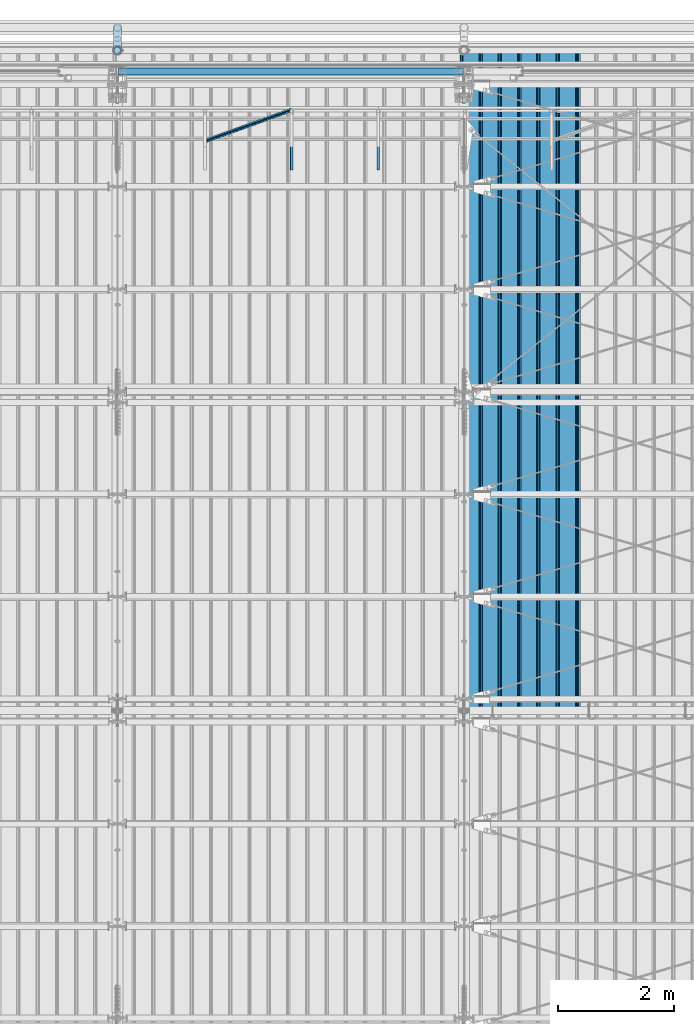
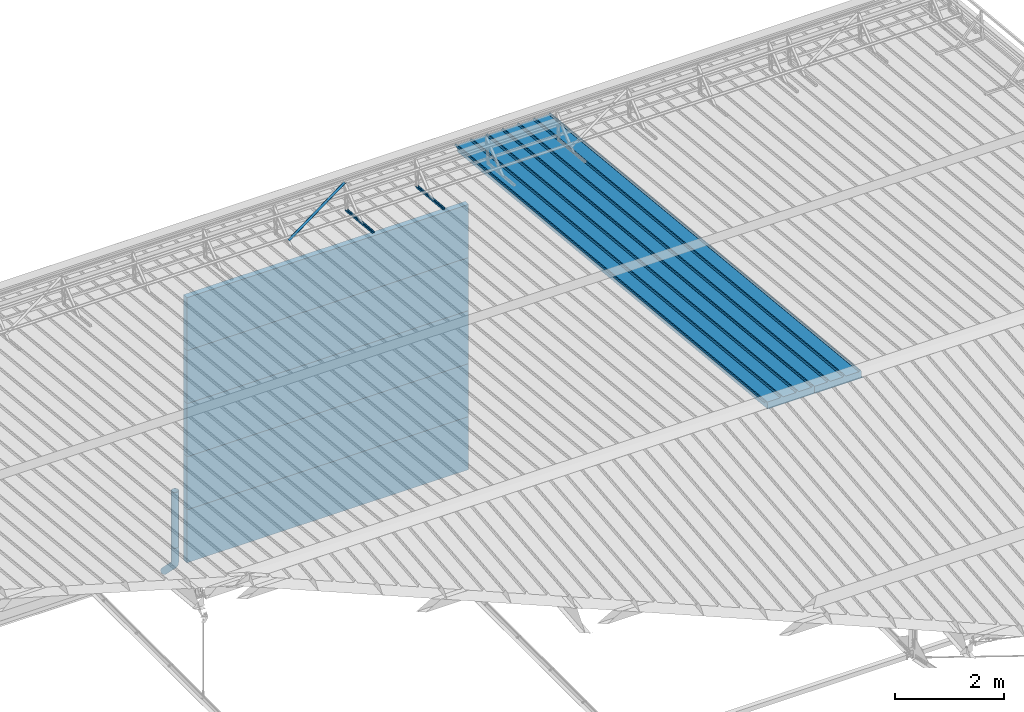
# One storey, part 76 of 709: 12 beams, 12 elements without a shape of their own.
"""IFC4 building model written with IfcOpenShell, lengths in millimetres."""

import ifcopenshell
import ifcopenshell.guid

model = None  # the IFC model being written
_history = None  # IfcOwnerHistory: only IFC2X3 demands one
_inside = {}  # id of a spatial element -> (the spatial element, [elements in it])
_under = {}  # id of a project, library or spatial element -> (it, [spatial elements below it])
_declared = {}  # id of a project -> (the project, [libraries it declares])
_typed = {}  # id of a type object -> (the type object, [elements of that type])
_made_of = {}  # id of a material, layer set ... -> (it, [elements and type objects made of it])


def new_model(schema):
    """Start an empty IFC model of exactly this schema.

    Asked for "IFC4X3", IfcOpenShell would pick the latest addendum, in which some entities
    have other attributes; the version numbers below select the first issue.
    IFC2X3 requires an IfcOwnerHistory on every rooted entity: one is made here for all.
    """
    global model, _history
    if schema == "IFC4X3":
        model = ifcopenshell.file(schema_version=(4, 3, 0, 0))
    else:
        model = ifcopenshell.file(schema=schema)
    _inside.clear()
    _under.clear()
    _declared.clear()
    _typed.clear()
    _made_of.clear()
    _history = None
    if model.schema == "IFC2X3":
        org = make("IfcOrganization", Name="unknown")
        user = make(
            "IfcPersonAndOrganization",
            ThePerson=make("IfcPerson", FamilyName="unknown"),
            TheOrganization=org,
        )
        app = make(
            "IfcApplication",
            ApplicationDeveloper=org,
            Version="unknown",
            ApplicationFullName="unknown",
            ApplicationIdentifier="unknown",
        )
        _history = make(
            "IfcOwnerHistory",
            OwningUser=user,
            OwningApplication=app,
            ChangeAction="ADDED",
            CreationDate=0,
        )
    return model


def make(cls, **values):
    """One entity of the class cls with the attributes given. An attribute that is None is left unset."""
    return model.create_entity(
        cls, **{name: value for name, value in values.items() if value is not None}
    )


def entity(cls, *values):
    """Any entity or typed value of the class cls, its attributes in the order of the schema. None: left unset."""
    e = model.create_entity(cls)
    for i, value in enumerate(values):
        if value is not None:
            e[i] = value
    return e


def rooted(cls, **values):
    """An entity with a GlobalId (a new one), such as an element, a storey or a relation."""
    return make(cls, GlobalId=ifcopenshell.guid.new(), OwnerHistory=_history, **values)


def si_unit(unit_type, name, prefix=None):
    """IfcSIUnit, for example si_unit("LENGTHUNIT", "METRE", prefix="MILLI")."""
    return make("IfcSIUnit", UnitType=unit_type, Prefix=prefix, Name=name)


def assignment(units):
    """IfcUnitAssignment: the units of a project."""
    return None if units is None else make("IfcUnitAssignment", Units=units)


def point(xyz):
    """IfcCartesianPoint."""
    return None if xyz is None else make("IfcCartesianPoint", Coordinates=xyz)


def direction(xyz):
    """IfcDirection."""
    return None if xyz is None else make("IfcDirection", DirectionRatios=xyz)


def frame(location, z_axis=None, x_axis=None):
    """IfcAxis2Placement3D, a coordinate frame: its origin and axes. An axis left out is left unset."""
    return make(
        "IfcAxis2Placement3D",
        Location=point(location),
        Axis=direction(z_axis),
        RefDirection=direction(x_axis),
    )


def origin_with_axes():
    """The frame at (0, 0, 0) with the z axis (0, 0, 1) and the x axis (1, 0, 0) written out."""
    return frame((0.0, 0.0, 0.0), z_axis=(0.0, 0.0, 1.0), x_axis=(1.0, 0.0, 0.0))


def place(relative_to, where):
    """IfcLocalPlacement: puts the frame where relative to a parent placement (None: the world)."""
    return make(
        "IfcLocalPlacement", PlacementRelTo=relative_to, RelativePlacement=where
    )


def context(
    kind, dimensions, precision=None, world=None, true_north=None, identifier=None
):
    """IfcGeometricRepresentationContext, for example the 3D "Model" context."""
    return make(
        "IfcGeometricRepresentationContext",
        ContextIdentifier=identifier,
        ContextType=kind,
        CoordinateSpaceDimension=dimensions,
        Precision=precision,
        WorldCoordinateSystem=world,
        TrueNorth=true_north,
    )


def subcontext(parent, identifier, kind, view, scale=None):
    """IfcGeometricRepresentationSubContext, for example "Body" below "Model"."""
    return make(
        "IfcGeometricRepresentationSubContext",
        ContextIdentifier=identifier,
        ContextType=kind,
        ParentContext=parent,
        TargetScale=scale,
        TargetView=view,
    )


def project(units=None, contexts=None):
    """IfcProject with its units and contexts."""
    return rooted(
        "IfcProject",
        Name="project",
        RepresentationContexts=contexts,
        UnitsInContext=assignment(units),
    )


def spatial(cls, under=None, at=None, **own):
    """A site, building, storey or space (cls), placed at a placement, below another one or the project."""
    s = rooted(cls, ObjectPlacement=at, **own)
    if under is not None:
        _under.setdefault(under.id(), (under, []))[1].append(s)
    return s


def point_list(points):
    """IfcCartesianPointList2D or 3D."""
    cls = (
        "IfcCartesianPointList2D" if len(points[0]) == 2 else "IfcCartesianPointList3D"
    )
    return make(cls, CoordList=points)


def line(*indices):
    """IfcLineIndex: a straight run through numbered points of an indexed curve."""
    return model.create_entity("IfcLineIndex", indices)


def indexed_curve(points, segments=None, self_intersect=None):
    """IfcIndexedPolyCurve: lines and arcs through numbered points (the first is 1)."""
    return make(
        "IfcIndexedPolyCurve",
        Points=point_list(points),
        Segments=segments,
        SelfIntersect=self_intersect,
    )


def outline(outer, holes=None, kind="AREA"):
    """IfcArbitraryClosedProfileDef: a profile drawn as a closed curve; with holes, ...WithVoids."""
    if holes is None:
        return make("IfcArbitraryClosedProfileDef", ProfileType=kind, OuterCurve=outer)
    return make(
        "IfcArbitraryProfileDefWithVoids",
        ProfileType=kind,
        OuterCurve=outer,
        InnerCurves=holes,
    )


def extrude(swept, where, along, depth):
    """IfcExtrudedAreaSolid: the profile swept, set in the frame where, extruded along a direction by depth."""
    return make(
        "IfcExtrudedAreaSolid",
        SweptArea=swept,
        Position=where,
        ExtrudedDirection=direction(along),
        Depth=depth,
    )


def shape(context_of_items, identifier, shape_type, items):
    """IfcShapeRepresentation: the items that make up one representation, for example the "Body"."""
    return make(
        "IfcShapeRepresentation",
        ContextOfItems=context_of_items,
        RepresentationIdentifier=identifier,
        RepresentationType=shape_type,
        Items=items,
    )


def material(Name=None, Category=None):
    """IfcMaterial."""
    return make("IfcMaterial", Name=Name, Category=Category)


def made_of(thing, what):
    """Note that an element or type object is made of a material, layer set ...; save() writes the relation."""
    if what is not None:
        _made_of.setdefault(what.id(), (what, []))[1].append(thing)
    return thing


def element(
    cls,
    number,
    at=None,
    inside=None,
    cuts=None,
    type_object=None,
    material=None,
    context=None,
    identifier="Body",
    shape_type=None,
    held_by="IfcProductDefinitionShape",
    body=None,
    shapes=None,
    **own,
):
    """One element of the class cls, such as IfcWall. Its Tag is "e" and its number.

    at: its placement. inside: the storey or other place that contains it. cuts: it is an
    opening in that element (IfcRelVoidsElement). A single representation is given by context,
    identifier, shape_type and body (its items); several are given by shapes. held_by: the class
    of the entity that holds the representations. save() writes the other relations.
    """
    e = rooted(cls, Tag="e%d" % number, ObjectPlacement=at, **own)
    if body is not None:
        shapes = [shape(context, identifier, shape_type, body)]
    if shapes is not None:
        e.Representation = make(held_by, Representations=shapes)
    if inside is not None:
        _inside.setdefault(inside.id(), (inside, []))[1].append(e)
    if cuts is not None:
        rooted(
            "IfcRelVoidsElement", RelatingBuildingElement=cuts, RelatedOpeningElement=e
        )
    if type_object is not None:
        _typed.setdefault(type_object.id(), (type_object, []))[1].append(e)
    return made_of(e, material)


def aggregate(whole, parts):
    """IfcRelAggregates: a whole, such as a stair, and the parts it consists of."""
    return rooted("IfcRelAggregates", RelatingObject=whole, RelatedObjects=parts)


def save(model, path):
    """Write the relations noted so far, then the file.

    IfcRelAggregates (storeys below a building ...), IfcRelContainedInSpatialStructure (elements
    in a storey), IfcRelDefinesByType, IfcRelAssociatesMaterial and IfcRelDeclares: one each for
    every whole, place, type object, material and project.
    """
    for whole, parts in _under.values():
        aggregate(whole, parts)
    for where, things in _inside.values():
        rooted(
            "IfcRelContainedInSpatialStructure",
            RelatedElements=things,
            RelatingStructure=where,
        )
    for kind, things in _typed.values():
        rooted("IfcRelDefinesByType", RelatedObjects=things, RelatingType=kind)
    for what, things in _made_of.values():
        rooted("IfcRelAssociatesMaterial", RelatedObjects=things, RelatingMaterial=what)
    for by, libraries in _declared.values():
        rooted("IfcRelDeclares", RelatingContext=by, RelatedDefinitions=libraries)
    model.write(path)


model = new_model("IFC4")

# Units and contexts
model_context = context("Model", 3, precision=0.2, world=origin_with_axes(), true_north=direction((0.0, 1.0)))
body_context = subcontext(model_context, "Body", "Model", "MODEL_VIEW")
ifc_project = project(units=[si_unit("LENGTHUNIT", "METRE", prefix="MILLI"), si_unit("AREAUNIT", "SQUARE_METRE"), si_unit("VOLUMEUNIT", "CUBIC_METRE"), si_unit("MASSUNIT", "GRAM", prefix="KILO"), si_unit("TIMEUNIT", "SECOND"), si_unit("PLANEANGLEUNIT", "RADIAN"), si_unit("SOLIDANGLEUNIT", "STERADIAN"), si_unit("THERMODYNAMICTEMPERATUREUNIT", "DEGREE_CELSIUS"), si_unit("LUMINOUSINTENSITYUNIT", "LUMEN")], contexts=[model_context])

# Site, building, storey
site_placement = place(None, origin_with_axes())
site = spatial("IfcSite", under=ifc_project, at=site_placement, CompositionType="ELEMENT")
building_placement = place(site_placement, origin_with_axes())
building = spatial("IfcBuilding", under=site, at=building_placement, Name="Undefined", CompositionType="ELEMENT")
storey_placement = place(building_placement, origin_with_axes())
storey = spatial("IfcBuildingStorey", under=building, at=storey_placement, Name="Undefined", CompositionType="ELEMENT", Elevation=0.0)

# Assembly, beam
assembly_1_placement = place(storey_placement, frame((41452.44, 11009.10459, 8419.96887), z_axis=(1.0, 0.0, 0.0), x_axis=(0.0, 0.9950371902, -0.099503719)))
assembly_1 = element("IfcElementAssembly", 1, at=assembly_1_placement, inside=storey)
ifc_material_1 = material(Name="Insulation", Category="Insulation")
beam_1_placement = place(assembly_1_placement, origin_with_axes())
beam_1 = element("IfcBeam", 2, at=beam_1_placement, material=ifc_material_1, ObjectType="P-99", context=body_context, shape_type="SolidModel", body=[
    extrude(outline(indexed_curve([(-509.8453, 89.5), (-490.1547, 89.5), (-471.67949, 57.5), (-471.67949, -88.5), (-436.67949, -88.5), (-436.67949, -91.5), (562.55841, -91.5), (562.55841, -89.5), (527.55841, -89.5), (527.55841, 57.5), (510.2379, 88.5), (489.7621, 88.5), (472.44159, 58.5), (196.71923, 58.5), (177.66667, 91.5), (155.66667, 91.5), (136.61411, 58.5), (-136.61411, 58.5), (-155.66667, 91.5), (-177.66667, 91.5), (-196.71923, 58.5), (-469.94744, 58.5), (-489.0, 91.5), (-511.0, 91.5), (-527.16581, 63.5), (-525.43376, 62.5)], segments=[line(1, 2, 3, 4, 5, 6, 7, 8, 9, 10, 11, 12, 13, 14, 15, 16, 17, 18, 19, 20, 21, 22, 23, 24, 25, 26, 1)])), frame((0.0, 0.0, 0.0), z_axis=(-1.0, 0.0, 0.0), x_axis=(0.0, 0.0, 1.0)), (0.0, 0.0, -1.0), 11459.0),
])
aggregate(assembly_1, [beam_1])

assembly_2_placement = place(storey_placement, frame((40452.44, 11009.10459, 8419.96887), z_axis=(1.0, 0.0, 0.0), x_axis=(0.0, 0.9950371902, -0.099503719)))
assembly_2 = element("IfcElementAssembly", 3, at=assembly_2_placement, inside=storey)
beam_2_placement = place(assembly_2_placement, origin_with_axes())
beam_2 = element("IfcBeam", 4, at=beam_2_placement, material=ifc_material_1, ObjectType="P-99", context=body_context, shape_type="SolidModel", body=[
    extrude(outline(indexed_curve([(-509.8453, 89.5), (-490.1547, 89.5), (-471.67949, 57.5), (-471.67949, -88.5), (-436.67949, -88.5), (-436.67949, -91.5), (562.55841, -91.5), (562.55841, -89.5), (527.55841, -89.5), (527.55841, 57.5), (510.2379, 88.5), (489.7621, 88.5), (472.44159, 58.5), (196.71923, 58.5), (177.66667, 91.5), (155.66667, 91.5), (136.61411, 58.5), (-136.61411, 58.5), (-155.66667, 91.5), (-177.66667, 91.5), (-196.71923, 58.5), (-469.94744, 58.5), (-489.0, 91.5), (-511.0, 91.5), (-527.16581, 63.5), (-525.43376, 62.5)], segments=[line(1, 2, 3, 4, 5, 6, 7, 8, 9, 10, 11, 12, 13, 14, 15, 16, 17, 18, 19, 20, 21, 22, 23, 24, 25, 26, 1)])), frame((0.0, 0.0, 0.0), z_axis=(-1.0, 0.0, 0.0), x_axis=(0.0, 0.0, 1.0)), (0.0, 0.0, -1.0), 11459.0),
])
aggregate(assembly_2, [beam_2])

assembly_3_placement = place(storey_placement, frame((38515.0, 21349.29926, 7565.33969), z_axis=(0.0, 0.099503719, 0.9950371902), x_axis=(0.0, -0.9950371902, 0.099503719)))
assembly_3 = element("IfcElementAssembly", 5, at=assembly_3_placement, inside=storey)
ifc_material_2 = material(Name="Steel_Undefined", Category="STEEL")
beam_3_placement = place(assembly_3_placement, origin_with_axes())
beam_3 = element("IfcBeam", 6, at=beam_3_placement, material=ifc_material_2, ObjectType="601", context=body_context, shape_type="SolidModel", body=[
    extrude(outline(indexed_curve([(-20.0, -25.0), (20.0, -25.0), (20.0, -22.5), (-17.5, -22.5), (-17.5, 22.5), (20.0, 22.5), (20.0, 25.0), (-20.0, 25.0)], segments=[line(1, 2, 3, 4, 5, 6, 7, 8, 1)])), frame((0.0, 0.0, 0.0), z_axis=(-1.0, 0.0, 0.0), x_axis=(0.0, 0.0, 1.0)), (0.0, 0.0, -1.0), 1000.0),
])
aggregate(assembly_3, [beam_3])

assembly_4_placement = place(storey_placement, frame((37015.0, 21349.29926, 7565.33969), z_axis=(0.0, 0.099503719, 0.9950371902), x_axis=(0.0, -0.9950371902, 0.099503719)))
assembly_4 = element("IfcElementAssembly", 7, at=assembly_4_placement, inside=storey)
beam_4_placement = place(assembly_4_placement, origin_with_axes())
beam_4 = element("IfcBeam", 8, at=beam_4_placement, material=ifc_material_2, ObjectType="601", context=body_context, shape_type="SolidModel", body=[
    extrude(outline(indexed_curve([(-20.0, -25.0), (20.0, -25.0), (20.0, -22.5), (-17.5, -22.5), (-17.5, 22.5), (20.0, 22.5), (20.0, 25.0), (-20.0, 25.0)], segments=[line(1, 2, 3, 4, 5, 6, 7, 8, 1)])), frame((0.0, 0.0, 0.0), z_axis=(-1.0, 0.0, 0.0), x_axis=(0.0, 0.0, 1.0)), (0.0, 0.0, -1.0), 1000.0),
])
aggregate(assembly_4, [beam_4])

assembly_5_placement = place(storey_placement, frame((37015.0, 21394.34666, 8157.9404), z_axis=(0.0, -0.6332377902, 0.7739572992), x_axis=(-0.9061831398, -0.3272952929, -0.2677870579)))
assembly_5 = element("IfcElementAssembly", 9, at=assembly_5_placement, inside=storey)
beam_5_placement = place(assembly_5_placement, origin_with_axes())
beam_5 = element("IfcBeam", 10, at=beam_5_placement, material=ifc_material_2, ObjectType="605", context=body_context, shape_type="SolidModel", body=[
    extrude(outline(indexed_curve([(-20.0, -25.0), (20.0, -25.0), (20.0, -22.5), (-17.5, -22.5), (-17.5, 22.5), (20.0, 22.5), (20.0, 25.0), (-20.0, 25.0)], segments=[line(1, 2, 3, 4, 5, 6, 7, 8, 1)])), frame((0.0, 0.0, 0.0), z_axis=(-1.0, 0.0, 0.0), x_axis=(0.0, 0.0, 1.0)), (0.0, 0.0, -1.0), 1655.29454),
])
aggregate(assembly_5, [beam_5])

assembly_6_placement = place(storey_placement, frame((34010.0, 22060.0, 895.0), z_axis=(0.0, 0.0, -1.0), x_axis=(1.0, 0.0, 0.0)))
assembly_6 = element("IfcElementAssembly", 11, at=assembly_6_placement, inside=storey)
beam_6_placement = place(assembly_6_placement, origin_with_axes())
beam_6 = element("IfcBeam", 12, at=beam_6_placement, material=ifc_material_1, ObjectType="P-107", context=body_context, shape_type="SolidModel", body=[
    extrude(outline(indexed_curve([(-595.0, -60.0), (595.0, -60.0), (595.0, 60.0), (-595.0, 60.0)], segments=[line(1, 2, 3, 4, 1)])), frame((0.0, 0.0, 0.0), z_axis=(-1.0, 0.0, 0.0), x_axis=(0.0, 0.0, 1.0)), (0.0, 0.0, -1.0), 5980.0),
])
aggregate(assembly_6, [beam_6])

assembly_7_placement = place(storey_placement, frame((34010.0, 22060.0, 2085.0), z_axis=(0.0, 0.0, -1.0), x_axis=(1.0, 0.0, 0.0)))
assembly_7 = element("IfcElementAssembly", 13, at=assembly_7_placement, inside=storey)
beam_7_placement = place(assembly_7_placement, origin_with_axes())
beam_7 = element("IfcBeam", 14, at=beam_7_placement, material=ifc_material_1, ObjectType="P-107", context=body_context, shape_type="SolidModel", body=[
    extrude(outline(indexed_curve([(-595.0, -60.0), (595.0, -60.0), (595.0, 60.0), (-595.0, 60.0)], segments=[line(1, 2, 3, 4, 1)])), frame((0.0, 0.0, 0.0), z_axis=(-1.0, 0.0, 0.0), x_axis=(0.0, 0.0, 1.0)), (0.0, 0.0, -1.0), 5980.0),
])
aggregate(assembly_7, [beam_7])

assembly_8_placement = place(storey_placement, frame((34010.0, 22060.0, 3275.0), z_axis=(0.0, 0.0, -1.0), x_axis=(1.0, 0.0, 0.0)))
assembly_8 = element("IfcElementAssembly", 15, at=assembly_8_placement, inside=storey)
beam_8_placement = place(assembly_8_placement, origin_with_axes())
beam_8 = element("IfcBeam", 16, at=beam_8_placement, material=ifc_material_1, ObjectType="P-107", context=body_context, shape_type="SolidModel", body=[
    extrude(outline(indexed_curve([(-595.0, -60.0), (595.0, -60.0), (595.0, 60.0), (-595.0, 60.0)], segments=[line(1, 2, 3, 4, 1)])), frame((0.0, 0.0, 0.0), z_axis=(-1.0, 0.0, 0.0), x_axis=(0.0, 0.0, 1.0)), (0.0, 0.0, -1.0), 5980.0),
])
aggregate(assembly_8, [beam_8])

assembly_9_placement = place(storey_placement, frame((34010.0, 22060.0, 4465.0), z_axis=(0.0, 0.0, -1.0), x_axis=(1.0, 0.0, 0.0)))
assembly_9 = element("IfcElementAssembly", 17, at=assembly_9_placement, inside=storey)
beam_9_placement = place(assembly_9_placement, origin_with_axes())
beam_9 = element("IfcBeam", 18, at=beam_9_placement, material=ifc_material_1, ObjectType="P-107", context=body_context, shape_type="SolidModel", body=[
    extrude(outline(indexed_curve([(-595.0, -60.0), (595.0, -60.0), (595.0, 60.0), (-595.0, 60.0)], segments=[line(1, 2, 3, 4, 1)])), frame((0.0, 0.0, 0.0), z_axis=(-1.0, 0.0, 0.0), x_axis=(0.0, 0.0, 1.0)), (0.0, 0.0, -1.0), 5980.0),
])
aggregate(assembly_9, [beam_9])

assembly_10_placement = place(storey_placement, frame((34010.0, 22060.0, 5655.0), z_axis=(0.0, 0.0, -1.0), x_axis=(1.0, 0.0, 0.0)))
assembly_10 = element("IfcElementAssembly", 19, at=assembly_10_placement, inside=storey)
beam_10_placement = place(assembly_10_placement, origin_with_axes())
beam_10 = element("IfcBeam", 20, at=beam_10_placement, material=ifc_material_1, ObjectType="P-107", context=body_context, shape_type="SolidModel", body=[
    extrude(outline(indexed_curve([(-595.0, -60.0), (595.0, -60.0), (595.0, 60.0), (-595.0, 60.0)], segments=[line(1, 2, 3, 4, 1)])), frame((0.0, 0.0, 0.0), z_axis=(-1.0, 0.0, 0.0), x_axis=(0.0, 0.0, 1.0)), (0.0, 0.0, -1.0), 5980.0),
])
aggregate(assembly_10, [beam_10])

assembly_11_placement = place(storey_placement, frame((34000.0, 22420.0, 1676.92297), z_axis=(0.0, -1.0, 0.0), x_axis=(0.0, 0.0, -1.0)))
assembly_11 = element("IfcElementAssembly", 21, at=assembly_11_placement, inside=storey)
beam_11_placement = place(assembly_11_placement, origin_with_axes())
beam_11 = element("IfcBeam", 22, at=beam_11_placement, material=ifc_material_2, ObjectType="614", context=body_context, shape_type="SolidModel", body=[
    extrude(outline(indexed_curve([(70.0, 0.0), (69.61653, 7.31699), (68.47033, 14.55382), (66.57396, 21.63119), (63.94818, 28.47157), (60.62178, 35.0), (56.63119, 41.14497), (52.02014, 46.83914), (46.83914, 52.02014), (41.14497, 56.63119), (35.0, 60.62178), (28.47157, 63.94818), (21.63119, 66.57396), (14.55382, 68.47033), (7.31699, 69.61653), (0.0, 70.0), (-7.31699, 69.61653), (-14.55382, 68.47033), (-21.63119, 66.57396), (-28.47157, 63.94818), (-35.0, 60.62178), (-41.14497, 56.63119), (-46.83914, 52.02014), (-52.02014, 46.83914), (-56.63119, 41.14497), (-60.62178, 35.0), (-63.94818, 28.47157), (-66.57396, 21.63119), (-68.47033, 14.55382), (-69.61653, 7.31699), (-70.0, 0.0), (-69.61653, -7.31699), (-68.47033, -14.55382), (-66.57396, -21.63119), (-63.94818, -28.47157), (-60.62178, -35.0), (-56.63119, -41.14497), (-52.02014, -46.83914), (-46.83914, -52.02014), (-41.14497, -56.63119), (-35.0, -60.62178), (-28.47157, -63.94818), (-21.63119, -66.57396), (-14.55382, -68.47033), (-7.31699, -69.61653), (0.0, -70.0), (7.31699, -69.61653), (14.55382, -68.47033), (21.63119, -66.57396), (28.47157, -63.94818), (35.0, -60.62178), (41.14497, -56.63119), (46.83914, -52.02014), (52.02014, -46.83914), (56.63119, -41.14497), (60.62178, -35.0), (63.94818, -28.47157), (66.57396, -21.63119), (68.47033, -14.55382), (69.61653, -7.31699)], segments=[line(1, 2, 3, 4, 5, 6, 7, 8, 9, 10, 11, 12, 13, 14, 15, 16, 17, 18, 19, 20, 21, 22, 23, 24, 25, 26, 27, 28, 29, 30, 31, 32, 33, 34, 35, 36, 37, 38, 39, 40, 41, 42, 43, 44, 45, 46, 47, 48, 49, 50, 51, 52, 53, 54, 55, 56, 57, 58, 59, 60, 1)]), holes=[indexed_curve([(65.0, 0.0), (64.64392, -6.79435), (63.57959, -13.51426), (61.81867, -20.0861), (59.38045, -26.43788), (56.29165, -32.5), (52.5861, -38.20604), (48.30441, -43.49349), (43.49349, -48.30441), (38.20604, -52.5861), (32.5, -56.29165), (26.43788, -59.38045), (20.0861, -61.81867), (13.51426, -63.57959), (6.79435, -64.64392), (0.0, -65.0), (-6.79435, -64.64392), (-13.51426, -63.57959), (-20.0861, -61.81867), (-26.43788, -59.38045), (-32.5, -56.29165), (-38.20604, -52.5861), (-43.49349, -48.30441), (-48.30441, -43.49349), (-52.5861, -38.20604), (-56.29165, -32.5), (-59.38045, -26.43788), (-61.81867, -20.0861), (-63.57959, -13.51426), (-64.64392, -6.79435), (-65.0, 0.0), (-64.64392, 6.79435), (-63.57959, 13.51426), (-61.81867, 20.0861), (-59.38045, 26.43788), (-56.29165, 32.5), (-52.5861, 38.20604), (-48.30441, 43.49349), (-43.49349, 48.30441), (-38.20604, 52.5861), (-32.5, 56.29165), (-26.43788, 59.38045), (-20.0861, 61.81867), (-13.51426, 63.57959), (-6.79435, 64.64392), (0.0, 65.0), (6.79435, 64.64392), (13.51426, 63.57959), (20.0861, 61.81867), (26.43788, 59.38045), (32.5, 56.29165), (38.20604, 52.5861), (43.49349, 48.30441), (48.30441, 43.49349), (52.5861, 38.20604), (56.29165, 32.5), (59.38045, 26.43788), (61.81867, 20.0861), (63.57959, 13.51426), (64.64392, 6.79435)], segments=[line(1, 2, 3, 4, 5, 6, 7, 8, 9, 10, 11, 12, 13, 14, 15, 16, 17, 18, 19, 20, 21, 22, 23, 24, 25, 26, 27, 28, 29, 30, 31, 32, 33, 34, 35, 36, 37, 38, 39, 40, 41, 42, 43, 44, 45, 46, 47, 48, 49, 50, 51, 52, 53, 54, 55, 56, 57, 58, 59, 60, 1)])]), frame((0.0, 0.0, 0.0), z_axis=(-1.0, 0.0, 0.0), x_axis=(0.0, 0.0, 1.0)), (0.0, 0.0, -1.0), 1250.0),
])
aggregate(assembly_11, [beam_11])

assembly_12_placement = place(storey_placement, frame((34000.0, 22420.0, 526.92297), z_axis=(1.0, 0.0, 0.0), x_axis=(0.0, 0.0, -1.0)))
assembly_12 = element("IfcElementAssembly", 23, at=assembly_12_placement, inside=storey)
beam_12_placement = place(assembly_12_placement, origin_with_axes())
beam_12 = element("IfcBeam", 24, at=beam_12_placement, material=ifc_material_2, ObjectType="617", context=body_context, shape_type="SolidModel", body=[
    entity("IfcSweptDiskSolid", entity("IfcIndexedPolyCurve", entity("IfcCartesianPointList3D", [[0.0, 0.0, 0.0], [448.2233, 0.0, 0.0], [496.05873, 9.51506, 0.0], [536.61165, 36.61165, 0.0], [900.0, 400.0, 0.0]]), [entity("IfcLineIndex", [1, 2]), entity("IfcArcIndex", [2, 3, 4]), entity("IfcLineIndex", [4, 5])]), 70.0, 65.0),
])
aggregate(assembly_12, [beam_12])

save(model, "model.ifc")
